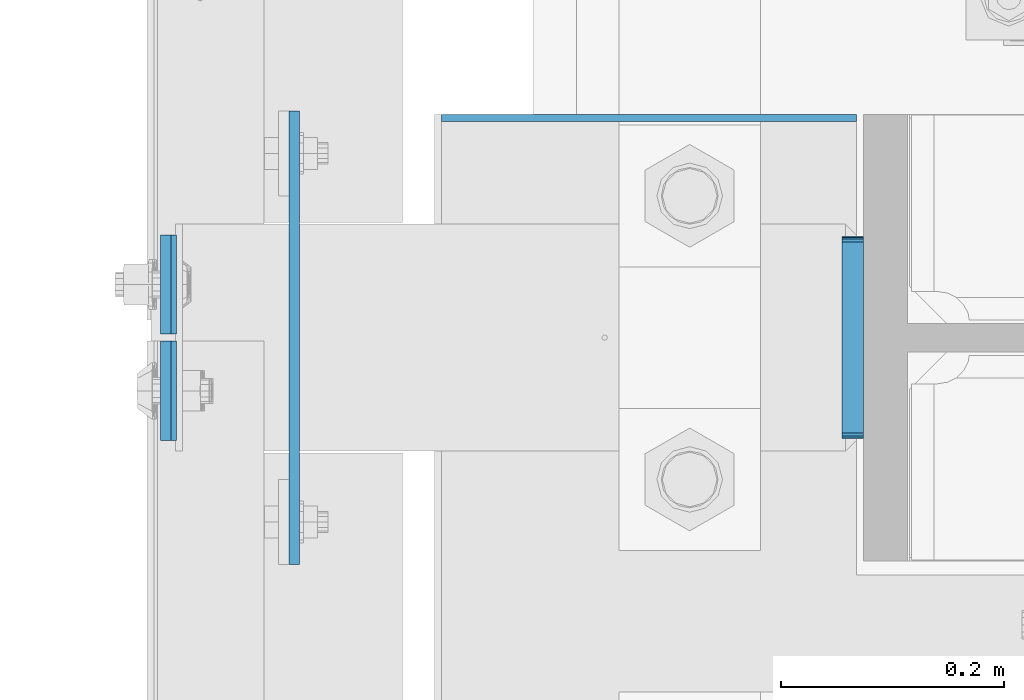
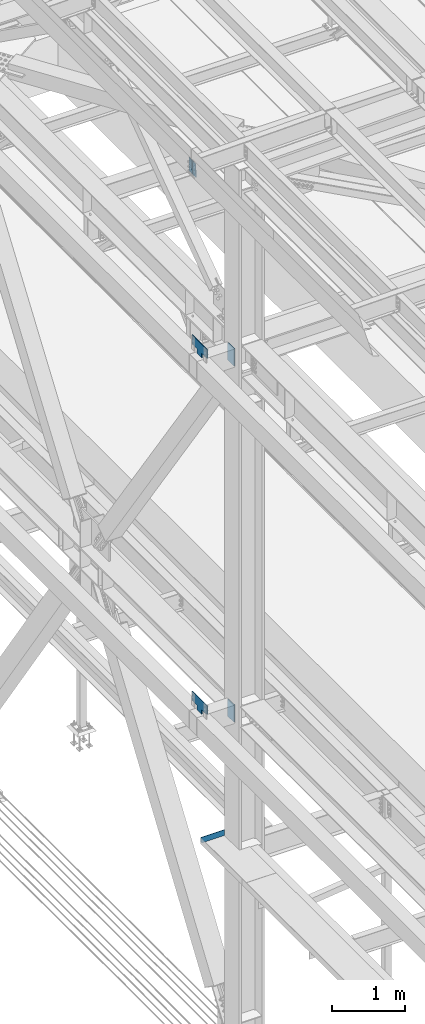
# One storey, part 3338 of 3843: 7 plates, 3 elements without a shape of their own.
"""IFC2X3 building model written with IfcOpenShell, lengths in millimetres."""

import ifcopenshell
import ifcopenshell.guid

model = None  # the IFC model being written
_history = None  # IfcOwnerHistory: only IFC2X3 demands one
_inside = {}  # id of a spatial element -> (the spatial element, [elements in it])
_under = {}  # id of a project, library or spatial element -> (it, [spatial elements below it])
_declared = {}  # id of a project -> (the project, [libraries it declares])
_typed = {}  # id of a type object -> (the type object, [elements of that type])
_made_of = {}  # id of a material, layer set ... -> (it, [elements and type objects made of it])


def new_model(schema):
    """Start an empty IFC model of exactly this schema.

    Asked for "IFC4X3", IfcOpenShell would pick the latest addendum, in which some entities
    have other attributes; the version numbers below select the first issue.
    IFC2X3 requires an IfcOwnerHistory on every rooted entity: one is made here for all.
    """
    global model, _history
    if schema == "IFC4X3":
        model = ifcopenshell.file(schema_version=(4, 3, 0, 0))
    else:
        model = ifcopenshell.file(schema=schema)
    _inside.clear()
    _under.clear()
    _declared.clear()
    _typed.clear()
    _made_of.clear()
    _history = None
    if model.schema == "IFC2X3":
        org = make("IfcOrganization", Name="unknown")
        user = make(
            "IfcPersonAndOrganization",
            ThePerson=make("IfcPerson", FamilyName="unknown"),
            TheOrganization=org,
        )
        app = make(
            "IfcApplication",
            ApplicationDeveloper=org,
            Version="unknown",
            ApplicationFullName="unknown",
            ApplicationIdentifier="unknown",
        )
        _history = make(
            "IfcOwnerHistory",
            OwningUser=user,
            OwningApplication=app,
            ChangeAction="ADDED",
            CreationDate=0,
        )
    return model


def make(cls, **values):
    """One entity of the class cls with the attributes given. An attribute that is None is left unset."""
    return model.create_entity(
        cls, **{name: value for name, value in values.items() if value is not None}
    )


def rooted(cls, **values):
    """An entity with a GlobalId (a new one), such as an element, a storey or a relation."""
    return make(cls, GlobalId=ifcopenshell.guid.new(), OwnerHistory=_history, **values)


def si_unit(unit_type, name, prefix=None):
    """IfcSIUnit, for example si_unit("LENGTHUNIT", "METRE", prefix="MILLI")."""
    return make("IfcSIUnit", UnitType=unit_type, Prefix=prefix, Name=name)


def assignment(units):
    """IfcUnitAssignment: the units of a project."""
    return None if units is None else make("IfcUnitAssignment", Units=units)


def point(xyz):
    """IfcCartesianPoint."""
    return None if xyz is None else make("IfcCartesianPoint", Coordinates=xyz)


def direction(xyz):
    """IfcDirection."""
    return None if xyz is None else make("IfcDirection", DirectionRatios=xyz)


def frame(location, z_axis=None, x_axis=None):
    """IfcAxis2Placement3D, a coordinate frame: its origin and axes. An axis left out is left unset."""
    return make(
        "IfcAxis2Placement3D",
        Location=point(location),
        Axis=direction(z_axis),
        RefDirection=direction(x_axis),
    )


def origin_with_axes():
    """The frame at (0, 0, 0) with the z axis (0, 0, 1) and the x axis (1, 0, 0) written out."""
    return frame((0.0, 0.0, 0.0), z_axis=(0.0, 0.0, 1.0), x_axis=(1.0, 0.0, 0.0))


def place(relative_to, where):
    """IfcLocalPlacement: puts the frame where relative to a parent placement (None: the world)."""
    return make(
        "IfcLocalPlacement", PlacementRelTo=relative_to, RelativePlacement=where
    )


def context(
    kind, dimensions, precision=None, world=None, true_north=None, identifier=None
):
    """IfcGeometricRepresentationContext, for example the 3D "Model" context."""
    return make(
        "IfcGeometricRepresentationContext",
        ContextIdentifier=identifier,
        ContextType=kind,
        CoordinateSpaceDimension=dimensions,
        Precision=precision,
        WorldCoordinateSystem=world,
        TrueNorth=true_north,
    )


def subcontext(parent, identifier, kind, view, scale=None):
    """IfcGeometricRepresentationSubContext, for example "Body" below "Model"."""
    return make(
        "IfcGeometricRepresentationSubContext",
        ContextIdentifier=identifier,
        ContextType=kind,
        ParentContext=parent,
        TargetScale=scale,
        TargetView=view,
    )


def project(units=None, contexts=None):
    """IfcProject with its units and contexts."""
    return rooted(
        "IfcProject",
        Name="project",
        RepresentationContexts=contexts,
        UnitsInContext=assignment(units),
    )


def spatial(cls, under=None, at=None, **own):
    """A site, building, storey or space (cls), placed at a placement, below another one or the project."""
    s = rooted(cls, ObjectPlacement=at, **own)
    if under is not None:
        _under.setdefault(under.id(), (under, []))[1].append(s)
    return s


def faces_of(points, faces, orient=None, outer=None):
    """IfcFace entities. A face is a list of loops; a loop is a list of indices into points, from 0.

    orient and outer hold one flag for each loop. By default every Orientation is true, the
    first loop of a face is its IfcFaceOuterBound and the others are IfcFaceBound.
    """
    made = []
    for i, loops in enumerate(faces):
        bounds = []
        for j, loop in enumerate(loops):
            is_outer = j == 0 if outer is None else outer[i][j]
            bounds.append(
                make(
                    "IfcFaceOuterBound" if is_outer else "IfcFaceBound",
                    Bound=make("IfcPolyLoop", Polygon=[points[k] for k in loop]),
                    Orientation=True if orient is None else orient[i][j],
                )
            )
        made.append(make("IfcFace", Bounds=bounds))
    return made


def faceted_brep(points, faces, orient=None, outer=None, voids=None):
    """IfcFacetedBrep: a solid bounded by flat faces; with voids (closed shells), ...WithVoids."""
    shared = [point(p) for p in points]
    hull = make("IfcClosedShell", CfsFaces=faces_of(shared, faces, orient, outer))
    if voids is None:
        return make("IfcFacetedBrep", Outer=hull)
    return make(
        "IfcFacetedBrepWithVoids",
        Outer=hull,
        Voids=[
            make(cls, CfsFaces=faces_of(shared, fs, o, b)) for cls, fs, o, b in voids
        ],
    )


def shape(context_of_items, identifier, shape_type, items):
    """IfcShapeRepresentation: the items that make up one representation, for example the "Body"."""
    return make(
        "IfcShapeRepresentation",
        ContextOfItems=context_of_items,
        RepresentationIdentifier=identifier,
        RepresentationType=shape_type,
        Items=items,
    )


def material(Name=None, Category=None):
    """IfcMaterial."""
    return make("IfcMaterial", Name=Name, Category=Category)


def made_of(thing, what):
    """Note that an element or type object is made of a material, layer set ...; save() writes the relation."""
    if what is not None:
        _made_of.setdefault(what.id(), (what, []))[1].append(thing)
    return thing


def type_object(cls, material=None, **own):
    """A type object (cls), such as IfcWallType, which elements share."""
    return made_of(rooted(cls, **own), material)


def element(
    cls,
    number,
    at=None,
    inside=None,
    cuts=None,
    type_object=None,
    material=None,
    context=None,
    identifier="Body",
    shape_type=None,
    held_by="IfcProductDefinitionShape",
    body=None,
    shapes=None,
    **own,
):
    """One element of the class cls, such as IfcWall. Its Tag is "e" and its number.

    at: its placement. inside: the storey or other place that contains it. cuts: it is an
    opening in that element (IfcRelVoidsElement). A single representation is given by context,
    identifier, shape_type and body (its items); several are given by shapes. held_by: the class
    of the entity that holds the representations. save() writes the other relations.
    """
    e = rooted(cls, Tag="e%d" % number, ObjectPlacement=at, **own)
    if body is not None:
        shapes = [shape(context, identifier, shape_type, body)]
    if shapes is not None:
        e.Representation = make(held_by, Representations=shapes)
    if inside is not None:
        _inside.setdefault(inside.id(), (inside, []))[1].append(e)
    if cuts is not None:
        rooted(
            "IfcRelVoidsElement", RelatingBuildingElement=cuts, RelatedOpeningElement=e
        )
    if type_object is not None:
        _typed.setdefault(type_object.id(), (type_object, []))[1].append(e)
    return made_of(e, material)


def aggregate(whole, parts):
    """IfcRelAggregates: a whole, such as a stair, and the parts it consists of."""
    return rooted("IfcRelAggregates", RelatingObject=whole, RelatedObjects=parts)


def save(model, path):
    """Write the relations noted so far, then the file.

    IfcRelAggregates (storeys below a building ...), IfcRelContainedInSpatialStructure (elements
    in a storey), IfcRelDefinesByType, IfcRelAssociatesMaterial and IfcRelDeclares: one each for
    every whole, place, type object, material and project.
    """
    for whole, parts in _under.values():
        aggregate(whole, parts)
    for where, things in _inside.values():
        rooted(
            "IfcRelContainedInSpatialStructure",
            RelatedElements=things,
            RelatingStructure=where,
        )
    for kind, things in _typed.values():
        rooted("IfcRelDefinesByType", RelatedObjects=things, RelatingType=kind)
    for what, things in _made_of.values():
        rooted("IfcRelAssociatesMaterial", RelatedObjects=things, RelatingMaterial=what)
    for by, libraries in _declared.values():
        rooted("IfcRelDeclares", RelatingContext=by, RelatedDefinitions=libraries)
    model.write(path)


model = new_model("IFC2X3")

# Units and contexts
model_context = context("Model", 3, precision=1e-05, world=origin_with_axes())
body_context = subcontext(model_context, "Body", "Model", "MODEL_VIEW")
ifc_project = project(units=[si_unit("LENGTHUNIT", "METRE", prefix="MILLI"), si_unit("AREAUNIT", "SQUARE_METRE"), si_unit("VOLUMEUNIT", "CUBIC_METRE"), si_unit("MASSUNIT", "GRAM", prefix="KILO"), si_unit("TIMEUNIT", "SECOND"), si_unit("PLANEANGLEUNIT", "RADIAN"), si_unit("SOLIDANGLEUNIT", "STERADIAN"), si_unit("THERMODYNAMICTEMPERATUREUNIT", "DEGREE_CELSIUS"), si_unit("LUMINOUSINTENSITYUNIT", "LUMEN")], contexts=[model_context])

# Site, building, storey
site_placement = place(None, origin_with_axes())
site = spatial("IfcSite", under=ifc_project, at=site_placement, CompositionType="ELEMENT")
building_placement = place(site_placement, origin_with_axes())
building = spatial("IfcBuilding", under=site, at=building_placement, Name="Undefined", CompositionType="ELEMENT")
storey_placement = place(building_placement, origin_with_axes())
storey = spatial("IfcBuildingStorey", under=building, at=storey_placement, Name="Undefined", CompositionType="ELEMENT", Elevation=0.0)

# Assembly, plates
assembly_1_placement = place(storey_placement, origin_with_axes())
assembly_1 = element("IfcElementAssembly", 1, at=assembly_1_placement, inside=storey, Name="BEAM", AssemblyPlace="NOTDEFINED", PredefinedType="RIGID_FRAME")
ifc_material = material(Name="STEEL/A572-50")
plate_type_1 = type_object("IfcPlateType", PredefinedType="NOTDEFINED")
plate_1_placement = place(assembly_1_placement, frame((35751.3030535202, 67268.725, 45674.0381290255), z_axis=(0.0, -1.0, 0.0), x_axis=(0.0211520550054438, 0.0, -0.999776270257025)))
plate_1 = element("IfcPlate", 2, at=plate_1_placement, type_object=plate_type_1, material=ifc_material, Name="PLATE", context=body_context, shape_type="Brep", body=[
    faceted_brep([(0.0, -4.76249999999709, 0.0), (0.0, -4.76249999999709, 88.9000015258789), (0.0, 4.76249999999709, 88.9000015258789), (0.0, 4.76249999999709, 0.0), (228.600006102781, -4.7625000004191, 88.9000015257589), (228.600006102781, 4.76249999954598, 88.9000015257443), (228.600006103079, -4.7625000004482, 7.27595761418343e-12), (228.600006103079, 4.76249999954598, -7.27595761418343e-12)], [[[0, 1, 2, 3]], [[1, 4, 5, 2]], [[4, 6, 7, 5]], [[6, 0, 3, 7]], [[5, 7, 3, 2]], [[6, 4, 1, 0]]]),
])
plate_2_placement = place(assembly_1_placement, frame((35751.3030535318, 67275.075, 45674.0381290355), z_axis=(0.0, 1.0, 0.0), x_axis=(0.0211520550054438, 0.0, -0.999776270257025)))
plate_2 = element("IfcPlate", 3, at=plate_2_placement, type_object=plate_type_1, material=ifc_material, Name="PLATE", context=body_context, shape_type="Brep", body=[
    faceted_brep([(0.0, -4.76249999999709, 0.0), (0.0, -4.76249999999709, 88.9000015258789), (0.0, 4.76249999999709, 88.9000015258789), (0.0, 4.76249999999709, 0.0), (228.600006102781, -4.7625000004191, 88.9000015257589), (228.600006102781, 4.76249999954598, 88.9000015257443), (228.600006103079, -4.7625000004482, 7.27595761418343e-12), (228.600006103079, 4.76249999954598, -7.27595761418343e-12)], [[[0, 1, 2, 3]], [[1, 4, 5, 2]], [[4, 6, 7, 5]], [[6, 0, 3, 7]], [[5, 7, 3, 2]], [[6, 4, 1, 0]]]),
])
aggregate(assembly_1, [plate_1, plate_2])

# Assembly, plate
assembly_2_placement = place(storey_placement, origin_with_axes())
assembly_2 = element("IfcElementAssembly", 4, at=assembly_2_placement, inside=storey, Name="BEAM", AssemblyPlace="NOTDEFINED", PredefinedType="RIGID_FRAME")
plate_type_2 = type_object("IfcPlateType", PredefinedType="NOTDEFINED")
plate_3_placement = place(assembly_2_placement, frame((35998.1500244141, 67468.75, 34042.35), z_axis=(0.0, 0.0, 1.0), x_axis=(1.0, 0.0, 0.0)))
plate_3 = element("IfcPlate", 5, at=plate_3_placement, type_object=plate_type_2, material=ifc_material, Name="PLATE", context=body_context, shape_type="Brep", body=[
    faceted_brep([(4.36557456851006e-11, -3.17499999998836, 19.0499992370969), (-2.44140610448085e-05, -3.17500000000291, 95.2499999999927), (-2.44140610448085e-05, 3.17500000000291, 95.2499999999927), (1.45519152283669e-11, 3.17499999998836, 19.0499992370824), (371.474975585938, -3.17500000000291, 95.2499999999927), (371.474975585938, 3.17500000000291, 95.2499999999927), (371.474975585938, -3.17500000000291, 0.0), (371.474975585938, 3.17500000000291, 0.0), (19.0499992370023, -3.17500000005384, 0.0), (19.0499992369587, 3.17499999992287, -1.45519152283669e-11)], [[[0, 1, 2, 3]], [[1, 4, 5, 2]], [[4, 6, 7, 5]], [[6, 8, 9, 7]], [[8, 0, 3, 9]], [[5, 7, 9, 3, 2]], [[8, 6, 4, 1, 0]]]),
])
aggregate(assembly_2, [plate_3])

# Assembly, plates
assembly_3_placement = place(storey_placement, origin_with_axes())
assembly_3 = element("IfcElementAssembly", 6, at=assembly_3_placement, inside=storey, Name="COLUMN", AssemblyPlace="NOTDEFINED", PredefinedType="RIGID_FRAME")
plate_type_3 = type_object("IfcPlateType", PredefinedType="NOTDEFINED")
plate_4_placement = place(assembly_3_placement, frame((35866.3875, 67335.4, 36404.55), z_axis=(0.0, 0.0, 1.0), x_axis=(0.0, -1.0, 0.0)))
plate_4 = element("IfcPlate", 7, at=plate_4_placement, type_object=plate_type_3, material=ifc_material, Name="PLATE", context=body_context, shape_type="Brep", body=[
    faceted_brep([(0.0, -4.76249999999709, 0.0), (-3.49245965480804e-10, -4.76249999999709, 76.1999999999462), (-3.49245965480804e-10, 4.76249999999709, 76.1999999999462), (0.0, 4.76249999999709, 0.0), (-139.699996948242, -4.76249999999709, 76.1999969482422), (-139.699996948242, 4.76249999999709, 76.1999969482422), (-139.699996948242, -4.76249999999709, 228.600006103516), (-139.699996948242, 4.76249999999709, 228.600006103516), (266.700012207031, -4.76249999999709, 228.600006103516), (266.700012207031, 4.76249999999709, 228.600006103516), (266.700012207031, -4.76249999999709, 76.1999969482422), (266.700012207031, 4.76249999999709, 76.1999969482422), (126.999992370605, -4.76249999999709, 76.1999969482422), (126.999992370605, 4.76249999999709, 76.1999969482422), (126.999992370605, -4.76249999999709, 0.0), (126.999992370605, 4.76249999999709, 0.0)], [[[0, 1, 2, 3]], [[1, 4, 5, 2]], [[4, 6, 7, 5]], [[6, 8, 9, 7]], [[8, 10, 11, 9]], [[10, 12, 13, 11]], [[12, 14, 15, 13]], [[14, 0, 3, 15]], [[5, 7, 9, 11, 13, 15, 3, 2]], [[14, 12, 10, 8, 6, 4, 1, 0]]]),
])
plate_5_placement = place(assembly_3_placement, frame((35866.3875, 67335.4, 42367.2), z_axis=(0.0, 0.0, 1.0), x_axis=(0.0, -1.0, 0.0)))
plate_5 = element("IfcPlate", 8, at=plate_5_placement, type_object=plate_type_3, material=ifc_material, Name="PLATE", context=body_context, shape_type="Brep", body=[
    faceted_brep([(0.0, -4.76249999999709, 0.0), (-3.49245965480804e-10, -4.76249999999709, 76.1999999999462), (-3.49245965480804e-10, 4.76249999999709, 76.1999999999462), (0.0, 4.76249999999709, 0.0), (-139.699996948242, -4.76249999999709, 76.1999969482422), (-139.699996948242, 4.76249999999709, 76.1999969482422), (-139.699996948242, -4.76249999999709, 228.600006103516), (-139.699996948242, 4.76249999999709, 228.600006103516), (266.700012207031, -4.76249999999709, 228.600006103516), (266.700012207031, 4.76249999999709, 228.600006103516), (266.700012207031, -4.76249999999709, 76.1999969482422), (266.700012207031, 4.76249999999709, 76.1999969482422), (126.999992370605, -4.76249999999709, 76.1999969482422), (126.999992370605, 4.76249999999709, 76.1999969482422), (126.999992370605, -4.76249999999709, 0.0), (126.999992370605, 4.76249999999709, 0.0)], [[[0, 1, 2, 3]], [[1, 4, 5, 2]], [[4, 6, 7, 5]], [[6, 8, 9, 7]], [[8, 10, 11, 9]], [[10, 12, 13, 11]], [[12, 14, 15, 13]], [[14, 0, 3, 15]], [[5, 7, 9, 11, 13, 15, 3, 2]], [[14, 12, 10, 8, 6, 4, 1, 0]]]),
])
plate_type_4 = type_object("IfcPlateType", PredefinedType="NOTDEFINED")
plate_6_placement = place(assembly_3_placement, frame((36366.45, 67181.4125, 42356.4551879883), z_axis=(0.0, 1.0, 0.0), x_axis=(0.0, 0.0, -1.0)))
plate_6 = element("IfcPlate", 9, at=plate_6_placement, type_object=plate_type_4, material=ifc_material, Name="PLATE", context=body_context, shape_type="Brep", body=[
    faceted_brep([(-8.22591685395256e-13, -9.52499999999854, 7.9375), (0.0, -9.52499999999418, 173.037499999991), (0.0, 9.52499999999418, 173.037499999991), (0.0, 9.52499999999418, 7.9375), (0.604206210693519, -9.52499999999418, 176.075049744395), (0.604206210693519, 9.52499999999418, 176.075049744395), (2.32483992433117, -9.52499999999418, 178.65016007566), (2.32483992433117, 9.52499999999418, 178.65016007566), (4.89995025560347, -9.52499999999418, 180.370793789305), (4.89995025560347, 9.52499999999418, 180.370793789305), (7.9375, -9.52499999999418, 180.974999999991), (7.9375, 9.52499999999418, 180.974999999991), (274.637499999997, -9.52499999999418, 180.974999999991), (274.637499999997, 9.52499999999418, 180.974999999991), (277.675049744394, -9.52499999999418, 180.370793789305), (277.675049744394, 9.52499999999418, 180.370793789305), (280.250160075666, -9.52499999999418, 178.65016007566), (280.250160075666, 9.52499999999418, 178.65016007566), (281.970793789304, -9.52499999999418, 176.075049744395), (281.970793789304, 9.52499999999418, 176.075049744395), (282.574999999997, -9.52499999999418, 173.037499999991), (282.574999999997, 9.52499999999418, 173.037499999991), (282.574999999997, -9.52499999999418, 7.9375), (282.574999999997, 9.52499999999418, 7.9375), (281.970793789304, -9.52499999999418, 4.8999502555962), (281.970793789304, 9.52499999999418, 4.8999502555962), (280.250160075666, -9.52499999999418, 2.32483992433117), (280.250160075666, 9.52499999999418, 2.32483992433117), (277.675049744394, -9.52499999999418, 0.604206210686243), (277.675049744394, 9.52499999999418, 0.604206210686243), (274.637499999997, -9.52499999999418, 0.0), (274.637499999997, 9.52499999999418, 0.0), (7.9375, -9.52499999999854, 0.0), (7.9375, 9.52499999999418, 0.0), (4.8999502555962, -9.52499999999418, 0.604206210693519), (4.8999502555962, 9.52499999999418, 0.604206210693519), (2.32483992433117, -9.52499999999418, 2.32483992433117), (2.32483992433117, 9.52499999999418, 2.32483992433117), (0.604206210686243, -9.52499999999418, 4.89995025560347), (0.604206210686243, 9.52499999999418, 4.89995025560347)], [[[0, 1, 2, 3]], [[1, 4, 5, 2]], [[4, 6, 7, 5]], [[6, 8, 9, 7]], [[8, 10, 11, 9]], [[10, 12, 13, 11]], [[12, 14, 15, 13]], [[14, 16, 17, 15]], [[16, 18, 19, 17]], [[18, 20, 21, 19]], [[20, 22, 23, 21]], [[22, 24, 25, 23]], [[24, 26, 27, 25]], [[26, 28, 29, 27]], [[28, 30, 31, 29]], [[30, 32, 33, 31]], [[32, 34, 35, 33]], [[34, 36, 37, 35]], [[36, 38, 39, 37]], [[38, 0, 3, 39]], [[5, 7, 9, 11, 13, 15, 17, 19, 21, 23, 25, 27, 29, 31, 33, 35, 37, 39, 3, 2]], [[38, 36, 34, 32, 30, 28, 26, 24, 22, 20, 18, 16, 14, 12, 10, 8, 6, 4, 1, 0]]]),
])
plate_7_placement = place(assembly_3_placement, frame((36366.45, 67181.4125, 36393.4375), z_axis=(0.0, 1.0, 0.0), x_axis=(0.0, 0.0, -1.0)))
plate_7 = element("IfcPlate", 10, at=plate_7_placement, type_object=plate_type_4, material=ifc_material, Name="PLATE", context=body_context, shape_type="Brep", body=[
    faceted_brep([(-8.22591685395256e-13, -9.52499999999854, 7.9375), (0.0, -9.52499999999418, 173.037499999991), (0.0, 9.52499999999418, 173.037499999991), (0.0, 9.52499999999418, 7.9375), (0.604206210693519, -9.52499999999418, 176.075049744395), (0.604206210693519, 9.52499999999418, 176.075049744395), (2.32483992433117, -9.52499999999418, 178.65016007566), (2.32483992433117, 9.52499999999418, 178.65016007566), (4.89995025560347, -9.52499999999418, 180.370793789305), (4.89995025560347, 9.52499999999418, 180.370793789305), (7.9375, -9.52499999999418, 180.974999999991), (7.9375, 9.52499999999418, 180.974999999991), (274.637499999997, -9.52499999999418, 180.974999999991), (274.637499999997, 9.52499999999418, 180.974999999991), (277.675049744394, -9.52499999999418, 180.370793789305), (277.675049744394, 9.52499999999418, 180.370793789305), (280.250160075666, -9.52499999999418, 178.65016007566), (280.250160075666, 9.52499999999418, 178.65016007566), (281.970793789304, -9.52499999999418, 176.075049744395), (281.970793789304, 9.52499999999418, 176.075049744395), (282.574999999997, -9.52499999999418, 173.037499999991), (282.574999999997, 9.52499999999418, 173.037499999991), (282.574999999997, -9.52499999999418, 7.9375), (282.574999999997, 9.52499999999418, 7.9375), (281.970793789304, -9.52499999999418, 4.8999502555962), (281.970793789304, 9.52499999999418, 4.8999502555962), (280.250160075666, -9.52499999999418, 2.32483992433117), (280.250160075666, 9.52499999999418, 2.32483992433117), (277.675049744394, -9.52499999999418, 0.604206210686243), (277.675049744394, 9.52499999999418, 0.604206210686243), (274.637499999997, -9.52499999999418, 0.0), (274.637499999997, 9.52499999999418, 0.0), (7.9375, -9.52499999999854, 0.0), (7.9375, 9.52499999999418, 0.0), (4.8999502555962, -9.52499999999418, 0.604206210693519), (4.8999502555962, 9.52499999999418, 0.604206210693519), (2.32483992433117, -9.52499999999418, 2.32483992433117), (2.32483992433117, 9.52499999999418, 2.32483992433117), (0.604206210686243, -9.52499999999418, 4.89995025560347), (0.604206210686243, 9.52499999999418, 4.89995025560347)], [[[0, 1, 2, 3]], [[1, 4, 5, 2]], [[4, 6, 7, 5]], [[6, 8, 9, 7]], [[8, 10, 11, 9]], [[10, 12, 13, 11]], [[12, 14, 15, 13]], [[14, 16, 17, 15]], [[16, 18, 19, 17]], [[18, 20, 21, 19]], [[20, 22, 23, 21]], [[22, 24, 25, 23]], [[24, 26, 27, 25]], [[26, 28, 29, 27]], [[28, 30, 31, 29]], [[30, 32, 33, 31]], [[32, 34, 35, 33]], [[34, 36, 37, 35]], [[36, 38, 39, 37]], [[38, 0, 3, 39]], [[5, 7, 9, 11, 13, 15, 17, 19, 21, 23, 25, 27, 29, 31, 33, 35, 37, 39, 3, 2]], [[38, 36, 34, 32, 30, 28, 26, 24, 22, 20, 18, 16, 14, 12, 10, 8, 6, 4, 1, 0]]]),
])
aggregate(assembly_3, [plate_6, plate_7, plate_4, plate_5])

save(model, "model.ifc")
